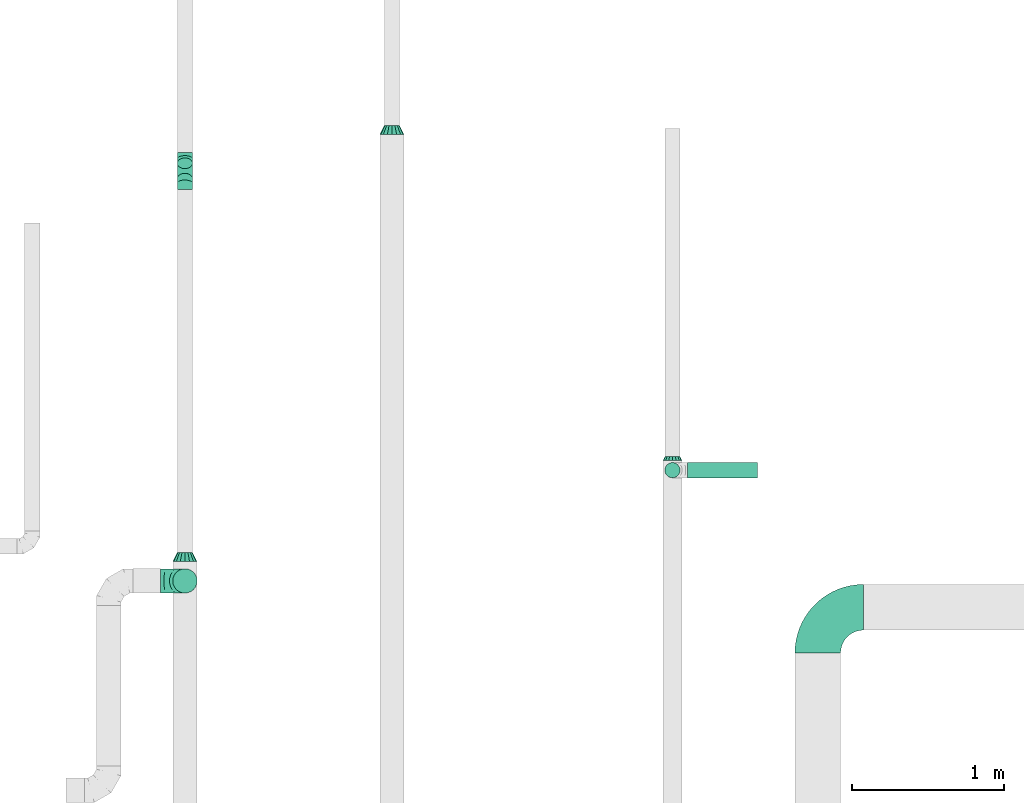
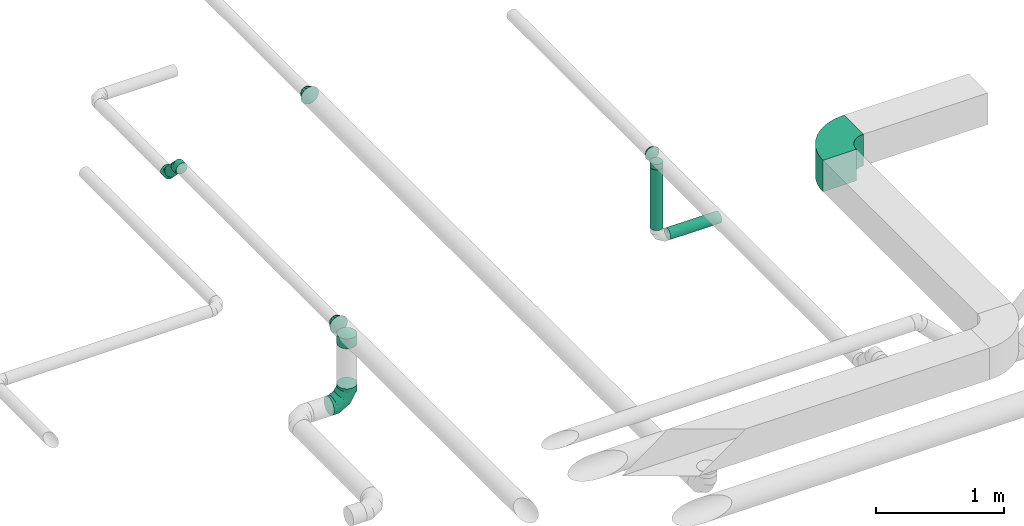
# One storey, part 19 of 60: 9 flow fittings, 3 flow segments.
"""IFC2X3 building model written with IfcOpenShell, lengths in millimetres."""

from ifc_helpers import new_model, entity, si_unit, converted_unit, derived_unit, direction, frame, frame_2d, origin, origin_2d_with_axis, place, context, subcontext, project, spatial, polyline, circle_curve, parameter, trimmed, segment, composite_curve, circle, outline, extrude, faceted_brep, source, transform, mapped, material, type_object, type_shapes, element, save


model = new_model("IFC2X3")

# Units and contexts
model_context = context("Model", 3, precision=0.01, world=origin(), true_north=direction((6.12303176911189e-17, 1.0)))
body_context = subcontext(model_context, "Body", "Model", "MODEL_VIEW")
ifc_project = project(units=[si_unit("LENGTHUNIT", "METRE", prefix="MILLI"), si_unit("AREAUNIT", "SQUARE_METRE"), si_unit("VOLUMEUNIT", "CUBIC_METRE"), converted_unit("PLANEANGLEUNIT", "DEGREE", entity("IfcRatioMeasure", 0.0174532925199433), si_unit("PLANEANGLEUNIT", "RADIAN"), dimensions=[0, 0, 0, 0, 0, 0, 0]), si_unit("MASSUNIT", "GRAM", prefix="KILO"), derived_unit("MASSDENSITYUNIT", [(si_unit("MASSUNIT", "GRAM", prefix="KILO"), 1), (si_unit("LENGTHUNIT", "METRE"), -3)]), derived_unit("MOMENTOFINERTIAUNIT", [(si_unit("LENGTHUNIT", "METRE"), 4)]), si_unit("TIMEUNIT", "SECOND"), si_unit("FREQUENCYUNIT", "HERTZ"), si_unit("THERMODYNAMICTEMPERATUREUNIT", "DEGREE_CELSIUS"), derived_unit("THERMALTRANSMITTANCEUNIT", [(si_unit("MASSUNIT", "GRAM", prefix="KILO"), 1), (si_unit("THERMODYNAMICTEMPERATUREUNIT", "KELVIN"), -1), (si_unit("TIMEUNIT", "SECOND"), -3)]), derived_unit("VOLUMETRICFLOWRATEUNIT", [(si_unit("LENGTHUNIT", "METRE"), 3), (si_unit("TIMEUNIT", "SECOND"), -1)]), derived_unit("MASSFLOWRATEUNIT", [(si_unit("MASSUNIT", "GRAM", prefix="KILO"), 1), (si_unit("TIMEUNIT", "SECOND"), -1)]), derived_unit("ROTATIONALFREQUENCYUNIT", [(si_unit("TIMEUNIT", "SECOND"), -1)]), si_unit("ELECTRICCURRENTUNIT", "AMPERE"), si_unit("ELECTRICVOLTAGEUNIT", "VOLT"), si_unit("POWERUNIT", "WATT"), si_unit("FORCEUNIT", "NEWTON", prefix="KILO"), si_unit("ILLUMINANCEUNIT", "LUX"), si_unit("LUMINOUSFLUXUNIT", "LUMEN"), si_unit("LUMINOUSINTENSITYUNIT", "CANDELA"), derived_unit("USERDEFINED", [(si_unit("MASSUNIT", "GRAM", prefix="KILO"), -1), (si_unit("LENGTHUNIT", "METRE"), -2), (si_unit("TIMEUNIT", "SECOND"), 3), (si_unit("LUMINOUSFLUXUNIT", "LUMEN"), 1)]), derived_unit("LINEARVELOCITYUNIT", [(si_unit("LENGTHUNIT", "METRE"), 1), (si_unit("TIMEUNIT", "SECOND"), -1)]), si_unit("PRESSUREUNIT", "PASCAL"), derived_unit("USERDEFINED", [(si_unit("LENGTHUNIT", "METRE"), -2), (si_unit("MASSUNIT", "GRAM", prefix="KILO"), 1), (si_unit("TIMEUNIT", "SECOND"), -2)]), derived_unit("LINEARFORCEUNIT", [(si_unit("MASSUNIT", "GRAM", prefix="KILO"), 1), (si_unit("LENGTHUNIT", "METRE"), 1), (si_unit("TIMEUNIT", "SECOND"), -2), (si_unit("LENGTHUNIT", "METRE"), -1)]), derived_unit("PLANARFORCEUNIT", [(si_unit("MASSUNIT", "GRAM", prefix="KILO"), 1), (si_unit("LENGTHUNIT", "METRE"), 1), (si_unit("TIMEUNIT", "SECOND"), -2), (si_unit("LENGTHUNIT", "METRE"), -2)])], contexts=[model_context])

# Site, building, storey
site_placement = place(None, origin())
site = spatial("IfcSite", under=ifc_project, at=site_placement, CompositionType="ELEMENT")
building_placement = place(site_placement, origin())
building = spatial("IfcBuilding", under=site, at=building_placement, CompositionType="ELEMENT")
storey_placement = place(building_placement, frame((0.0, 0.0, 19800.0)))
storey = spatial("IfcBuildingStorey", under=building, at=storey_placement, CompositionType="ELEMENT", Elevation=19800.0)

# Flow segments
duct_segment_type = type_object("IfcDuctSegmentType", PredefinedType="NOTDEFINED")
flow_segment_1_placement = place(storey_placement, frame((18543.74, 15577.52, 3032.34)))
element("IfcFlowSegment", 1, at=flow_segment_1_placement, inside=storey, type_object=duct_segment_type, context=body_context, shape_type="SweptSolid", body=[
    extrude(circle(Radius=50.0, at=origin_2d_with_axis()), frame((51.6, 36.95, 138.37), z_axis=(0.0, 0.707106781186543, -0.707106781186552), x_axis=(1.0, 0.0, 0.0)), (0.0, 0.0, 1.0), 143.431457505032),
])
flow_segment_2_placement = place(storey_placement, frame((21745.23, 13648.74, 2640.0)))
element("IfcFlowSegment", 2, at=flow_segment_2_placement, inside=storey, type_object=duct_segment_type, context=body_context, shape_type="SweptSolid", body=[
    extrude(circle(Radius=50.0, at=origin_2d_with_axis()), frame((51.6, 51.6, 0.0), z_axis=(0.0, 0.0, 1.0), x_axis=(-1.0, 0.0, 0.0)), (0.0, 0.0, 1.0), 577.499999999981),
])
flow_segment_3_placement = place(storey_placement, frame((21896.82, 13648.74, 2488.4)))
element("IfcFlowSegment", 3, at=flow_segment_3_placement, inside=storey, type_object=duct_segment_type, context=body_context, shape_type="SweptSolid", body=[
    extrude(circle(Radius=50.0, at=origin_2d_with_axis()), frame((0.0, 51.6, 51.6), z_axis=(1.0, 0.0, 0.0), x_axis=(0.0, -1.0, 0.0)), (0.0, 0.0, 1.0), 460.000000000008),
])

# Flow fittings
ifc_material = material()
duct_fitting_type_1 = type_object("IfcDuctFittingType", PredefinedType="NOTDEFINED", material=ifc_material)
shared_shape_1 = source(origin(), body_context, "Body", "Brep", [
    faceted_brep([(-160.0, 0.0, -80.0), (-160.0, -20.71, -77.27), (-160.0, -40.0, -69.28), (-160.0, -56.57, -56.57), (-160.0, -69.28, -40.0), (-160.0, -77.27, -20.71), (-160.0, -80.0, 0.0), (-160.0, -77.27, 20.71), (-160.0, -69.28, 40.0), (-160.0, -56.57, 56.57), (-160.0, -40.0, 69.28), (-160.0, -20.71, 77.27), (-160.0, 0.0, 80.0), (-160.0, 20.71, 77.27), (-160.0, 40.0, 69.28), (-160.0, 56.57, 56.57), (-160.0, 69.28, 40.0), (-160.0, 77.27, 20.71), (-160.0, 80.0, 0.0), (-160.0, 77.27, -20.71), (-160.0, 69.28, -40.0), (-160.0, 56.57, -56.57), (-160.0, 40.0, -69.28), (-160.0, 20.71, -77.27), (-122.68, 20.71, 77.27), (-127.85, 40.0, 69.28), (-117.13, 0.0, 80.0), (-132.29, 56.57, 56.57), (-137.83, 77.27, 20.71), (-138.56, 80.0, 0.0), (-135.69, 69.28, 40.0), (-135.69, 69.28, -40.0), (-132.29, 56.57, -56.57), (-137.83, 77.27, -20.71), (-122.68, 20.71, -77.27), (-117.13, 0.0, -80.0), (-127.85, 40.0, -69.28), (-111.58, -20.71, -77.27), (-106.41, -40.0, -69.28), (-101.97, -56.57, -56.57), (-98.56, -69.28, -40.0), (-96.42, -77.27, -20.71), (-95.69, -80.0, 0.0), (-96.42, -77.27, 20.71), (-98.56, -69.28, 40.0), (-101.97, -56.57, 56.57), (-106.41, -40.0, 69.28), (-111.58, -20.71, 77.27), (-58.03, 58.03, 77.27), (-72.15, 72.15, 69.28), (-42.87, 42.87, 80.0), (-84.28, 84.28, 56.57), (-93.59, 93.59, 40.0), (-99.44, 99.44, 20.71), (-101.44, 101.44, 0.0), (-99.44, 99.44, -20.71), (-93.59, 93.59, -40.0), (-84.28, 84.28, -56.57), (-58.03, 58.03, -77.27), (-42.87, 42.87, -80.0), (-72.15, 72.15, -69.28), (-27.71, 27.71, -77.27), (-13.59, 13.59, -69.28), (-1.46, 1.46, -56.57), (7.85, -7.85, -40.0), (13.7, -13.7, -20.71), (15.69, -15.69, 0.0), (13.7, -13.7, 20.71), (7.85, -7.85, 40.0), (-1.46, 1.46, 56.57), (-13.59, 13.59, 69.28), (-27.71, 27.71, 77.27), (-20.71, 122.68, 77.27), (-40.0, 127.85, 69.28), (0.0, 117.13, 80.0), (-56.57, 132.29, 56.57), (-69.28, 135.69, 40.0), (-77.27, 137.83, 20.71), (-80.0, 138.56, 0.0), (-77.27, 137.83, -20.71), (-69.28, 135.69, -40.0), (-56.57, 132.29, -56.57), (-20.71, 122.68, -77.27), (0.0, 117.13, -80.0), (-40.0, 127.85, -69.28), (20.71, 111.58, -77.27), (40.0, 106.41, -69.28), (56.57, 101.97, -56.57), (69.28, 98.56, -40.0), (77.27, 96.42, -20.71), (80.0, 95.69, 0.0), (77.27, 96.42, 20.71), (69.28, 98.56, 40.0), (56.57, 101.97, 56.57), (40.0, 106.41, 69.28), (20.71, 111.58, 77.27), (-20.71, 160.0, -77.27), (-40.0, 160.0, -69.28), (-56.57, 160.0, -56.57), (-69.28, 160.0, -40.0), (-77.27, 160.0, -20.71), (-80.0, 160.0, 0.0), (-77.27, 160.0, 20.71), (-69.28, 160.0, 40.0), (-56.57, 160.0, 56.57), (-40.0, 160.0, 69.28), (-20.71, 160.0, 77.27), (0.0, 160.0, 80.0), (20.71, 160.0, 77.27), (40.0, 160.0, 69.28), (56.57, 160.0, 56.57), (69.28, 160.0, 40.0), (77.27, 160.0, 20.71), (80.0, 160.0, 0.0), (77.27, 160.0, -20.71), (69.28, 160.0, -40.0), (56.57, 160.0, -56.57), (40.0, 160.0, -69.28), (20.71, 160.0, -77.27), (0.0, 160.0, -80.0)], [[[0, 1, 2, 3, 4, 5, 6, 7, 8, 9, 10, 11, 12, 13, 14, 15, 16, 17, 18, 19, 20, 21, 22, 23]], [[24, 25, 14, 13]], [[26, 24, 13, 12]], [[14, 25, 27, 15]], [[28, 29, 18, 17]], [[30, 28, 17, 16]], [[15, 27, 30, 16]], [[20, 31, 32, 21]], [[33, 31, 20, 19]], [[18, 29, 33, 19]], [[34, 35, 0, 23]], [[36, 34, 23, 22]], [[32, 36, 22, 21]], [[1, 0, 35, 37]], [[2, 1, 37, 38]], [[3, 2, 38, 39]], [[5, 4, 40, 41]], [[6, 5, 41, 42]], [[39, 40, 4, 3]], [[6, 42, 43, 7]], [[7, 43, 44, 8]], [[8, 44, 45, 9]], [[9, 45, 46, 10]], [[10, 46, 47, 11]], [[26, 12, 11, 47]], [[48, 49, 25, 24]], [[50, 48, 24, 26]], [[27, 25, 49, 51]], [[52, 53, 28, 30]], [[51, 52, 30, 27]], [[29, 28, 53, 54]], [[55, 56, 31, 33]], [[54, 55, 33, 29]], [[32, 31, 56, 57]], [[58, 59, 35, 34]], [[60, 58, 34, 36]], [[57, 60, 36, 32]], [[37, 35, 59, 61]], [[38, 37, 61, 62]], [[39, 38, 62, 63]], [[41, 40, 64, 65]], [[42, 41, 65, 66]], [[63, 64, 40, 39]], [[43, 42, 66, 67]], [[44, 43, 67, 68]], [[68, 69, 45, 44]], [[46, 45, 69, 70]], [[47, 46, 70, 71]], [[26, 47, 71, 50]], [[72, 73, 49, 48]], [[74, 72, 48, 50]], [[51, 49, 73, 75]], [[76, 77, 53, 52]], [[75, 76, 52, 51]], [[54, 53, 77, 78]], [[79, 80, 56, 55]], [[78, 79, 55, 54]], [[57, 56, 80, 81]], [[82, 83, 59, 58]], [[84, 82, 58, 60]], [[81, 84, 60, 57]], [[61, 59, 83, 85]], [[62, 61, 85, 86]], [[63, 62, 86, 87]], [[65, 64, 88, 89]], [[66, 65, 89, 90]], [[87, 88, 64, 63]], [[67, 66, 90, 91]], [[68, 67, 91, 92]], [[92, 93, 69, 68]], [[70, 69, 93, 94]], [[71, 70, 94, 95]], [[50, 71, 95, 74]], [[96, 97, 98, 99, 100, 101, 102, 103, 104, 105, 106, 107, 108, 109, 110, 111, 112, 113, 114, 115, 116, 117, 118, 119]], [[72, 74, 107, 106]], [[73, 72, 106, 105]], [[75, 73, 105, 104]], [[77, 76, 103, 102]], [[78, 77, 102, 101]], [[75, 104, 103, 76]], [[78, 101, 100, 79]], [[79, 100, 99, 80]], [[80, 99, 98, 81]], [[84, 97, 96, 82]], [[82, 96, 119, 83]], [[84, 81, 98, 97]], [[118, 117, 86, 85]], [[119, 118, 85, 83]], [[116, 87, 86, 117]], [[88, 115, 114, 89]], [[89, 114, 113, 90]], [[115, 88, 87, 116]], [[112, 111, 92, 91]], [[113, 112, 91, 90]], [[111, 110, 93, 92]], [[95, 94, 109, 108]], [[74, 95, 108, 107]], [[110, 109, 94, 93]]]),
])
type_shapes(duct_fitting_type_1, [shared_shape_1])
flow_fitting_1_placement = place(storey_placement, frame((18595.33, 12973.09, 2560.0), z_axis=(0.0, 1.0, 0.0), x_axis=(0.0, 0.0, -1.0)))
element("IfcFlowFitting", 4, at=flow_fitting_1_placement, inside=storey, type_object=duct_fitting_type_1, material=ifc_material, context=body_context, shape_type="MappedRepresentation", body=[
    mapped(shared_shape_1, transform((0.0, 0.0, 0.0), scale=1.0)),
])
duct_fitting_type_2 = type_object("IfcDuctFittingType", PredefinedType="NOTDEFINED", material=ifc_material)
shared_shape_2 = source(origin(), body_context, "Body", "Brep", [
    faceted_brep([(60.0, -46.19, 19.13), (60.0, -48.1, 9.57), (60.0, -50.0, 0.0), (60.0, -48.1, -9.57), (60.0, -46.19, -19.13), (60.0, -40.77, -27.24), (60.0, -35.36, -35.36), (60.0, -27.24, -40.77), (60.0, -19.13, -46.19), (60.0, -9.57, -48.1), (60.0, 0.0, -50.0), (60.0, 9.57, -48.1), (60.0, 19.13, -46.19), (60.0, 27.24, -40.77), (60.0, 35.36, -35.36), (60.0, 40.77, -27.24), (60.0, 46.19, -19.13), (60.0, 48.1, -9.57), (60.0, 50.0, 0.0), (60.0, 48.1, 9.57), (60.0, 46.19, 19.13), (60.0, 40.77, 27.24), (60.0, 35.36, 35.36), (60.0, 27.24, 40.77), (60.0, 19.13, 46.19), (60.0, 9.57, 48.1), (60.0, 0.0, 50.0), (60.0, -9.57, 48.1), (60.0, -19.13, 46.19), (60.0, -27.24, 40.77), (60.0, -35.36, 35.36), (60.0, -40.77, 27.24), (0.0, -80.0, 0.0), (0.0, -77.16, 14.27), (0.0, -73.91, 30.61), (0.0, -65.24, 43.59), (0.0, -56.57, 56.57), (0.0, -43.59, 65.24), (0.0, -30.61, 73.91), (0.0, -15.31, 76.96), (0.0, 0.0, 80.0), (0.0, 14.27, 77.16), (0.0, 30.61, 73.91), (0.0, 43.59, 65.24), (0.0, 56.57, 56.57), (0.0, 65.24, 43.59), (0.0, 73.91, 30.61), (0.0, 76.96, 15.31), (0.0, 80.0, 0.0), (0.0, 77.16, -14.27), (0.0, 73.91, -30.61), (0.0, 65.24, -43.59), (0.0, 56.57, -56.57), (0.0, 43.59, -65.24), (0.0, 30.61, -73.91), (0.0, 15.31, -76.96), (0.0, 0.0, -80.0), (0.0, -14.27, -77.16), (0.0, -30.61, -73.91), (0.0, -43.59, -65.24), (0.0, -56.57, -56.57), (0.0, -65.24, -43.59), (0.0, -73.91, -30.61), (0.0, -76.96, -15.31)], [[[0, 1, 2, 3, 4, 5, 6, 7, 8, 9, 10, 11, 12, 13, 14, 15, 16, 17, 18, 19, 20, 21, 22, 23, 24, 25, 26, 27, 28, 29, 30, 31]], [[32, 33, 34, 35, 36, 37, 38, 39, 40, 41, 42, 43, 44, 45, 46, 47, 48, 49, 50, 51, 52, 53, 54, 55, 56, 57, 58, 59, 60, 61, 62, 63]], [[42, 41, 40, 26, 25, 24]], [[43, 42, 24, 23, 22, 44]], [[20, 46, 45, 44, 22, 21]], [[18, 48, 47, 46, 20, 19]], [[34, 33, 32, 2, 1, 0]], [[35, 34, 0, 31, 30, 36]], [[28, 38, 37, 36, 30, 29]], [[26, 40, 39, 38, 28, 27]], [[58, 57, 56, 10, 9, 8]], [[59, 58, 8, 7, 6, 60]], [[4, 62, 61, 60, 6, 5]], [[2, 32, 63, 62, 4, 3]], [[50, 49, 48, 18, 17, 16]], [[51, 50, 16, 15, 14, 52]], [[12, 54, 53, 52, 14, 13]], [[10, 56, 55, 54, 12, 11]]]),
])
type_shapes(duct_fitting_type_2, [shared_shape_2])
for number, where, z_axis, x_axis in (
    (5, (19955.04, 15903.91, 3199.92), (0.0, 0.0, 1.0), (0.0, 1.0, 0.0)),
    (6, (18595.33, 13100.18, 3200.0), (0.0, 0.0, 1.0), (0.0, 1.0, 0.0)),
):
    element("IfcFlowFitting", number, at=place(storey_placement, frame(where, z_axis=z_axis, x_axis=x_axis)), inside=storey, type_object=duct_fitting_type_2, material=ifc_material, context=body_context, shape_type="MappedRepresentation", body=[
        mapped(shared_shape_2, transform((0.0, 0.0, 0.0), scale=1.0)),
    ])
duct_fitting_type_3 = type_object("IfcDuctFittingType", PredefinedType="NOTDEFINED", material=ifc_material)
shared_shape_3 = source(origin(), body_context, "Body", "Brep", [
    faceted_brep([(-41.42, 0.0, -50.0), (-41.42, -12.94, -48.3), (-41.42, -25.0, -43.3), (-41.42, -35.36, -35.36), (-41.42, -43.3, -25.0), (-41.42, -48.3, -12.94), (-41.42, -50.0, 0.0), (-41.42, -48.3, 12.94), (-41.42, -43.3, 25.0), (-41.42, -35.36, 35.36), (-41.42, -25.0, 43.3), (-41.42, -12.94, 48.3), (-41.42, 0.0, 50.0), (-41.42, 12.94, 48.3), (-41.42, 25.0, 43.3), (-41.42, 35.36, 35.36), (-41.42, 43.3, 25.0), (-41.42, 48.3, 12.94), (-41.42, 50.0, 0.0), (-41.42, 48.3, -12.94), (-41.42, 43.3, -25.0), (-41.42, 35.36, -35.36), (-41.42, 25.0, -43.3), (-41.42, 12.94, -48.3), (-5.36, 12.94, 48.3), (-10.36, 25.0, 43.3), (0.0, 0.0, 50.0), (-14.64, 35.36, 35.36), (-20.0, 48.3, 12.94), (-20.71, 50.0, 0.0), (-17.94, 43.3, 25.0), (-17.94, 43.3, -25.0), (-14.64, 35.36, -35.36), (-20.0, 48.3, -12.94), (-5.36, 12.94, -48.3), (0.0, 0.0, -50.0), (-10.36, 25.0, -43.3), (5.36, -12.94, -48.3), (10.36, -25.0, -43.3), (14.64, -35.36, -35.36), (17.94, -43.3, -25.0), (20.0, -48.3, -12.94), (20.71, -50.0, 0.0), (20.0, -48.3, 12.94), (17.94, -43.3, 25.0), (14.64, -35.36, 35.36), (10.36, -25.0, 43.3), (5.36, -12.94, 48.3), (29.29, 29.29, 50.0), (20.14, 38.44, 48.3), (11.61, 46.97, 43.3), (4.29, 54.29, 35.36), (-1.33, 59.91, 25.0), (-4.86, 63.44, 12.94), (-6.07, 64.64, 0.0), (-4.86, 63.44, -12.94), (-1.33, 59.91, -25.0), (4.29, 54.29, -35.36), (11.61, 46.97, -43.3), (20.14, 38.44, -48.3), (29.29, 29.29, -50.0), (38.44, 20.14, -48.3), (46.97, 11.61, -43.3), (54.29, 4.29, -35.36), (59.91, -1.33, -25.0), (63.44, -4.86, -12.94), (64.64, -6.07, 0.0), (63.44, -4.86, 12.94), (59.91, -1.33, 25.0), (54.29, 4.29, 35.36), (46.97, 11.61, 43.3), (38.44, 20.14, 48.3)], [[[0, 1, 2, 3, 4, 5, 6, 7, 8, 9, 10, 11, 12, 13, 14, 15, 16, 17, 18, 19, 20, 21, 22, 23]], [[24, 25, 14, 13]], [[26, 24, 13, 12]], [[14, 25, 27, 15]], [[28, 29, 18, 17]], [[30, 28, 17, 16]], [[16, 15, 27, 30]], [[20, 31, 32, 21]], [[33, 31, 20, 19]], [[18, 29, 33, 19]], [[34, 35, 0, 23]], [[36, 34, 23, 22]], [[32, 36, 22, 21]], [[1, 0, 35, 37]], [[2, 1, 37, 38]], [[38, 39, 3, 2]], [[5, 4, 40, 41]], [[6, 5, 41, 42]], [[39, 40, 4, 3]], [[6, 42, 43, 7]], [[7, 43, 44, 8]], [[8, 44, 45, 9]], [[9, 45, 46, 10]], [[10, 46, 47, 11]], [[26, 12, 11, 47]], [[24, 26, 48, 49]], [[25, 24, 49, 50]], [[27, 25, 50, 51]], [[28, 30, 52, 53]], [[29, 28, 53, 54]], [[27, 51, 52, 30]], [[29, 54, 55, 33]], [[33, 55, 56, 31]], [[31, 56, 57, 32]], [[36, 58, 59, 34]], [[34, 59, 60, 35]], [[36, 32, 57, 58]], [[61, 62, 38, 37]], [[60, 61, 37, 35]], [[63, 39, 38, 62]], [[40, 64, 65, 41]], [[41, 65, 66, 42]], [[64, 40, 39, 63]], [[43, 42, 66, 67]], [[44, 43, 67, 68]], [[68, 69, 45, 44]], [[47, 46, 70, 71]], [[26, 47, 71, 48]], [[69, 70, 46, 45]], [[59, 58, 57, 56, 55, 54, 53, 52, 51, 50, 49, 48, 71, 70, 69, 68, 67, 66, 65, 64, 63, 62, 61, 60]]]),
])
type_shapes(duct_fitting_type_3, [shared_shape_3])
for number, where, z_axis, x_axis in (
    (7, (18595.33, 15585.18, 3200.0), (-1.0, 0.0, 0.0), (0.0, 1.0, 0.0)),
    (8, (18595.33, 15745.18, 3040.0), (1.0, 0.0, 0.0), (0.0, 0.707106781186472, -0.707106781186623)),
):
    element("IfcFlowFitting", number, at=place(storey_placement, frame(where, z_axis=z_axis, x_axis=x_axis)), inside=storey, type_object=duct_fitting_type_3, material=ifc_material, context=body_context, shape_type="MappedRepresentation", body=[
        mapped(shared_shape_3, transform((0.0, 0.0, 0.0), scale=1.0)),
    ])
duct_fitting_type_4 = type_object("IfcDuctFittingType", PredefinedType="NOTDEFINED", material=ifc_material)
shared_shape_4 = source(origin(), body_context, "Body", "Brep", [
    faceted_brep([(25.0, -46.19, 19.13), (25.0, -48.1, 9.57), (25.0, -50.0, 0.0), (25.0, -48.1, -9.57), (25.0, -46.19, -19.13), (25.0, -40.77, -27.24), (25.0, -35.36, -35.36), (25.0, -27.24, -40.77), (25.0, -19.13, -46.19), (25.0, -9.57, -48.1), (25.0, 0.0, -50.0), (25.0, 9.57, -48.1), (25.0, 19.13, -46.19), (25.0, 27.24, -40.77), (25.0, 35.36, -35.36), (25.0, 40.77, -27.24), (25.0, 46.19, -19.13), (25.0, 48.1, -9.57), (25.0, 50.0, 0.0), (25.0, 48.1, 9.57), (25.0, 46.19, 19.13), (25.0, 40.77, 27.24), (25.0, 35.36, 35.36), (25.0, 27.24, 40.77), (25.0, 19.13, 46.19), (25.0, 9.57, 48.1), (25.0, 0.0, 50.0), (25.0, -9.57, 48.1), (25.0, -19.13, 46.19), (25.0, -27.24, 40.77), (25.0, -35.36, 35.36), (25.0, -40.77, 27.24), (0.0, -62.5, 0.0), (0.0, -60.02, 12.45), (0.0, -57.74, 23.92), (0.0, -50.97, 34.06), (0.0, -44.19, 44.19), (0.0, -34.06, 50.97), (0.0, -23.92, 57.74), (0.0, -12.45, 60.02), (0.0, 0.0, 62.5), (0.0, 12.45, 60.02), (0.0, 23.92, 57.74), (0.0, 34.06, 50.97), (0.0, 44.19, 44.19), (0.0, 50.97, 34.06), (0.0, 57.74, 23.92), (0.0, 60.02, 12.45), (0.0, 62.5, 0.0), (0.0, 60.02, -12.45), (0.0, 57.74, -23.92), (0.0, 50.97, -34.06), (0.0, 44.19, -44.19), (0.0, 34.06, -50.97), (0.0, 23.92, -57.74), (0.0, 12.45, -60.02), (0.0, 0.0, -62.5), (0.0, -12.45, -60.02), (0.0, -23.92, -57.74), (0.0, -34.06, -50.97), (0.0, -44.19, -44.19), (0.0, -50.97, -34.06), (0.0, -57.74, -23.92), (0.0, -60.02, -12.45)], [[[0, 1, 2, 3, 4, 5, 6, 7, 8, 9, 10, 11, 12, 13, 14, 15, 16, 17, 18, 19, 20, 21, 22, 23, 24, 25, 26, 27, 28, 29, 30, 31]], [[32, 33, 34, 35, 36, 37, 38, 39, 40, 41, 42, 43, 44, 45, 46, 47, 48, 49, 50, 51, 52, 53, 54, 55, 56, 57, 58, 59, 60, 61, 62, 63]], [[24, 42, 41, 40, 26, 25]], [[22, 44, 43, 42, 24, 23]], [[48, 47, 46, 20, 19, 18]], [[44, 22, 21, 20, 46, 45]], [[0, 34, 33, 32, 2, 1]], [[30, 36, 35, 34, 0, 31]], [[40, 39, 38, 28, 27, 26]], [[36, 30, 29, 28, 38, 37]], [[8, 58, 57, 56, 10, 9]], [[6, 60, 59, 58, 8, 7]], [[32, 63, 62, 4, 3, 2]], [[60, 6, 5, 4, 62, 61]], [[16, 50, 49, 48, 18, 17]], [[14, 52, 51, 50, 16, 15]], [[56, 55, 54, 12, 11, 10]], [[52, 14, 13, 12, 54, 53]]]),
])
type_shapes(duct_fitting_type_4, [shared_shape_4])
flow_fitting_2_placement = place(storey_placement, frame((21796.82, 13764.7, 3300.0), z_axis=(0.0, 0.0, 1.0), x_axis=(0.0, 1.0, 0.0)))
element("IfcFlowFitting", 9, at=flow_fitting_2_placement, inside=storey, type_object=duct_fitting_type_4, material=ifc_material, context=body_context, shape_type="MappedRepresentation", body=[
    mapped(shared_shape_4, transform((0.0, 0.0, 0.0), scale=1.0)),
])
duct_fitting_type_5 = type_object("IfcDuctFittingType", PredefinedType="NOTDEFINED", material=ifc_material)
shared_shape_5 = source(origin(), body_context, "Body", "Brep", [
    faceted_brep([(20.0, 0.0, -80.0), (20.0, 20.71, -77.27), (20.0, 40.0, -69.28), (20.0, 56.57, -56.57), (20.0, 69.28, -40.0), (20.0, 77.27, -20.71), (20.0, 80.0, 0.0), (20.0, 77.27, 20.71), (20.0, 69.28, 40.0), (20.0, 56.57, 56.57), (20.0, 40.0, 69.28), (20.0, 20.71, 77.27), (20.0, 0.0, 80.0), (20.0, -20.71, 77.27), (20.0, -40.0, 69.28), (20.0, -56.57, 56.57), (20.0, -69.28, 40.0), (20.0, -77.27, 20.71), (20.0, -80.0, 0.0), (20.0, -77.27, -20.71), (20.0, -69.28, -40.0), (20.0, -56.57, -56.57), (20.0, -40.0, -69.28), (20.0, -20.71, -77.27), (0.0, 0.0, 80.0), (-73.9, 0.0, 80.0), (-73.9, -20.71, 77.27), (0.0, -20.71, 77.27), (-73.9, -40.0, 69.28), (0.0, -40.0, 69.28), (0.0, -56.57, 56.57), (-73.9, -56.57, 56.57), (0.0, -69.28, 40.0), (-73.9, -69.28, 40.0), (-73.9, -77.27, 20.71), (0.0, -77.27, 20.71), (-73.9, -80.0, 0.0), (0.0, -80.0, 0.0), (-73.9, -77.27, -20.71), (0.0, -77.27, -20.71), (-73.9, -69.28, -40.0), (0.0, -69.28, -40.0), (0.0, -56.57, -56.57), (-73.9, -56.57, -56.57), (0.0, -40.0, -69.28), (-73.9, -40.0, -69.28), (-73.9, -20.71, -77.27), (0.0, -20.71, -77.27), (-73.9, 0.0, -80.0), (0.0, 0.0, -80.0), (-73.9, 20.71, -77.27), (0.0, 20.71, -77.27), (-73.9, 40.0, -69.28), (0.0, 40.0, -69.28), (0.0, 56.57, -56.57), (-73.9, 56.57, -56.57), (0.0, 69.28, -40.0), (-73.9, 69.28, -40.0), (-73.9, 77.27, -20.71), (0.0, 77.27, -20.71), (-73.9, 80.0, 0.0), (0.0, 80.0, 0.0), (-73.9, 77.27, 20.71), (0.0, 77.27, 20.71), (-73.9, 69.28, 40.0), (0.0, 69.28, 40.0), (0.0, 56.57, 56.57), (-73.9, 56.57, 56.57), (0.0, 40.0, 69.28), (-73.9, 40.0, 69.28), (-73.9, 20.71, 77.27), (0.0, 20.71, 77.27)], [[[0, 1, 2, 3, 4, 5, 6, 7, 8, 9, 10, 11, 12, 13, 14, 15, 16, 17, 18, 19, 20, 21, 22, 23]], [[13, 12, 24, 25, 26, 27]], [[14, 13, 27, 26, 28, 29]], [[30, 15, 14, 29, 28, 31]], [[17, 16, 32, 33, 34, 35]], [[18, 17, 35, 34, 36, 37]], [[32, 16, 15, 30, 31, 33]], [[19, 18, 37, 36, 38, 39]], [[20, 19, 39, 38, 40, 41]], [[42, 21, 20, 41, 40, 43]], [[23, 22, 44, 45, 46, 47]], [[0, 23, 47, 46, 48, 49]], [[44, 22, 21, 42, 43, 45]], [[1, 0, 49, 48, 50, 51]], [[2, 1, 51, 50, 52, 53]], [[54, 3, 2, 53, 52, 55]], [[5, 4, 56, 57, 58, 59]], [[6, 5, 59, 58, 60, 61]], [[56, 4, 3, 54, 55, 57]], [[7, 6, 61, 60, 62, 63]], [[8, 7, 63, 62, 64, 65]], [[66, 9, 8, 65, 64, 67]], [[11, 10, 68, 69, 70, 71]], [[12, 11, 71, 70, 25, 24]], [[68, 10, 9, 66, 67, 69]], [[46, 45, 43, 40, 38, 36, 34, 33, 31, 28, 26, 25, 70, 69, 67, 64, 62, 60, 58, 57, 55, 52, 50, 48]]]),
])
type_shapes(duct_fitting_type_5, [shared_shape_5])
flow_fitting_3_placement = place(storey_placement, frame((18595.33, 12973.09, 3120.0), z_axis=(0.0, 1.0, 0.0), x_axis=(0.0, 0.0, -1.0)))
element("IfcFlowFitting", 10, at=flow_fitting_3_placement, inside=storey, type_object=duct_fitting_type_5, material=ifc_material, context=body_context, shape_type="MappedRepresentation", body=[
    mapped(shared_shape_5, transform((0.0, 0.0, 0.0), scale=1.0)),
])
duct_fitting_type_6 = type_object("IfcDuctFittingType", PredefinedType="NOTDEFINED", material=ifc_material)
shared_shape_6 = source(origin(), body_context, "Body", "Brep", [
    faceted_brep([(20.0, 0.0, -50.0), (20.0, 12.94, -48.3), (20.0, 25.0, -43.3), (20.0, 35.36, -35.36), (20.0, 43.3, -25.0), (20.0, 48.3, -12.94), (20.0, 50.0, 0.0), (20.0, 48.3, 12.94), (20.0, 43.3, 25.0), (20.0, 35.36, 35.36), (20.0, 25.0, 43.3), (20.0, 12.94, 48.3), (20.0, 0.0, 50.0), (20.0, -12.94, 48.3), (20.0, -25.0, 43.3), (20.0, -35.36, 35.36), (20.0, -43.3, 25.0), (20.0, -48.3, 12.94), (20.0, -50.0, 0.0), (20.0, -48.3, -12.94), (20.0, -43.3, -25.0), (20.0, -35.36, -35.36), (20.0, -25.0, -43.3), (20.0, -12.94, -48.3), (0.0, 0.0, 50.0), (-31.1, 0.0, 50.0), (-31.1, -12.94, 48.3), (0.0, -12.94, 48.3), (-31.1, -25.0, 43.3), (0.0, -25.0, 43.3), (0.0, -35.36, 35.36), (-31.1, -35.36, 35.36), (0.0, -43.3, 25.0), (-31.1, -43.3, 25.0), (-31.1, -48.3, 12.94), (0.0, -48.3, 12.94), (-31.1, -50.0, 0.0), (0.0, -50.0, 0.0), (-31.1, -48.3, -12.94), (0.0, -48.3, -12.94), (-31.1, -43.3, -25.0), (0.0, -43.3, -25.0), (0.0, -35.36, -35.36), (-31.1, -35.36, -35.36), (0.0, -25.0, -43.3), (-31.1, -25.0, -43.3), (-31.1, -12.94, -48.3), (0.0, -12.94, -48.3), (-31.1, 0.0, -50.0), (0.0, 0.0, -50.0), (-31.1, 12.94, -48.3), (0.0, 12.94, -48.3), (-31.1, 25.0, -43.3), (0.0, 25.0, -43.3), (0.0, 35.36, -35.36), (-31.1, 35.36, -35.36), (0.0, 43.3, -25.0), (-31.1, 43.3, -25.0), (-31.1, 48.3, -12.94), (0.0, 48.3, -12.94), (-31.1, 50.0, 0.0), (0.0, 50.0, 0.0), (-31.1, 48.3, 12.94), (0.0, 48.3, 12.94), (-31.1, 43.3, 25.0), (0.0, 43.3, 25.0), (0.0, 35.36, 35.36), (-31.1, 35.36, 35.36), (0.0, 25.0, 43.3), (-31.1, 25.0, 43.3), (-31.1, 12.94, 48.3), (0.0, 12.94, 48.3)], [[[0, 1, 2, 3, 4, 5, 6, 7, 8, 9, 10, 11, 12, 13, 14, 15, 16, 17, 18, 19, 20, 21, 22, 23]], [[13, 12, 24, 25, 26, 27]], [[14, 13, 27, 26, 28, 29]], [[30, 15, 14, 29, 28, 31]], [[17, 16, 32, 33, 34, 35]], [[18, 17, 35, 34, 36, 37]], [[32, 16, 15, 30, 31, 33]], [[19, 18, 37, 36, 38, 39]], [[20, 19, 39, 38, 40, 41]], [[42, 21, 20, 41, 40, 43]], [[23, 22, 44, 45, 46, 47]], [[0, 23, 47, 46, 48, 49]], [[44, 22, 21, 42, 43, 45]], [[1, 0, 49, 48, 50, 51]], [[2, 1, 51, 50, 52, 53]], [[54, 3, 2, 53, 52, 55]], [[5, 4, 56, 57, 58, 59]], [[6, 5, 59, 58, 60, 61]], [[56, 4, 3, 54, 55, 57]], [[7, 6, 61, 60, 62, 63]], [[8, 7, 63, 62, 64, 65]], [[66, 9, 8, 65, 64, 67]], [[11, 10, 68, 69, 70, 71]], [[12, 11, 71, 70, 25, 24]], [[68, 10, 9, 66, 67, 69]], [[46, 45, 43, 40, 38, 36, 34, 33, 31, 28, 26, 25, 70, 69, 67, 64, 62, 60, 58, 57, 55, 52, 50, 48]]]),
])
type_shapes(duct_fitting_type_6, [shared_shape_6])
flow_fitting_4_placement = place(storey_placement, frame((21796.82, 13700.33, 3237.5), z_axis=(0.0, -1.0, 0.0), x_axis=(0.0, 0.0, -1.0)))
element("IfcFlowFitting", 11, at=flow_fitting_4_placement, inside=storey, type_object=duct_fitting_type_6, material=ifc_material, context=body_context, shape_type="MappedRepresentation", body=[
    mapped(shared_shape_6, transform((0.0, 0.0, 0.0), scale=1.0)),
])
duct_fitting_type_7 = type_object("IfcDuctFittingType", PredefinedType="NOTDEFINED", material=ifc_material)
shared_shape_7 = source(origin(), body_context, "Body", "SweptSolid", [
    extrude(outline(composite_curve([segment(polyline([(-300.0, -150.0), (0.0, -150.0)]), True, "CONTINUOUS"), segment(trimmed(circle_curve(frame_2d((150.0, -150.0), x_axis=(0.0, 1.0)), 150.0), [parameter(0.0)], [parameter(90.0)], True, "PARAMETER"), False, "CONTINUOUS"), segment(polyline([(150.0, 0.0), (150.0, 300.0)]), True, "CONTINUOUS"), segment(trimmed(circle_curve(frame_2d((150.0, -150.0), x_axis=(0.0, 1.0)), 450.0), [parameter(0.0)], [parameter(90.0000000000001)], True, "PARAMETER"), True, "CONTINUOUS")], self_intersect=False)), frame((-150.0, 150.0, -150.0), z_axis=(0.0, 0.0, 1.0), x_axis=(-1.0, 0.0, 0.0)), (0.0, 0.0, 1.0), 300.0),
])
type_shapes(duct_fitting_type_7, [shared_shape_7])
flow_fitting_5_placement = place(storey_placement, frame((22750.9, 12800.16, 3570.0), z_axis=(0.0, 0.0, 1.0), x_axis=(-1.0, 0.0, 0.0)))
element("IfcFlowFitting", 12, at=flow_fitting_5_placement, inside=storey, type_object=duct_fitting_type_7, material=ifc_material, context=body_context, shape_type="MappedRepresentation", body=[
    mapped(shared_shape_7, transform((0.0, 0.0, 0.0), scale=1.0)),
])

save(model, "model.ifc")
